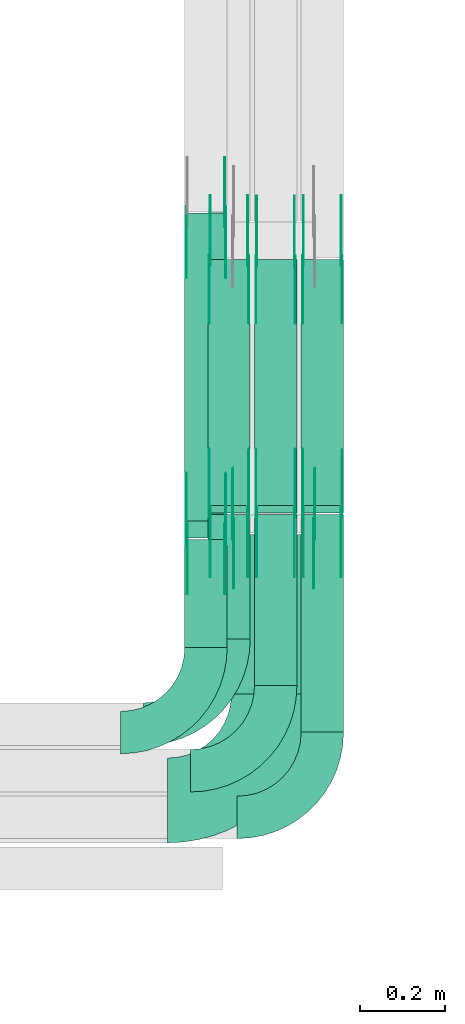
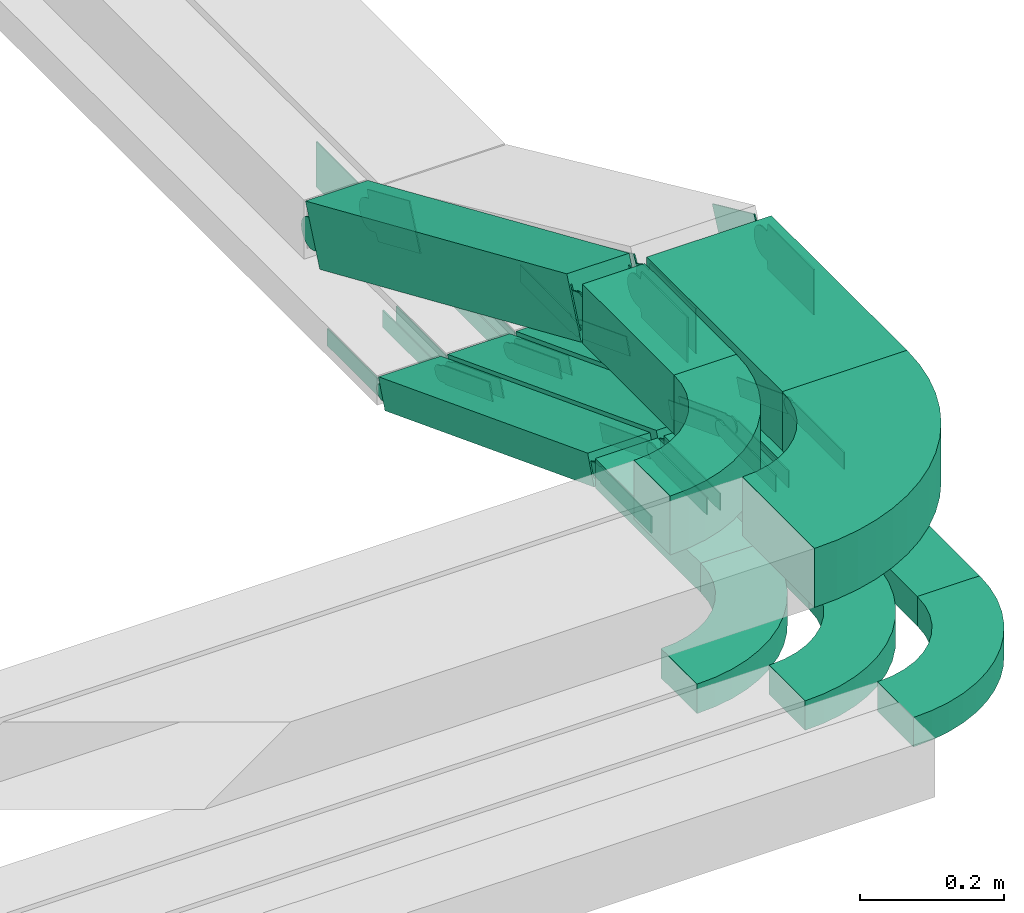
# One storey, part 19 of 25: 40 flow fittings, 9 flow segments.
"""IFC2X3 building model written with IfcOpenShell, lengths in millimetres."""

from ifc_helpers import new_model, entity, si_unit, converted_unit, derived_unit, direction, frame, frame_2d, origin, origin_2d_with_axis, place, context, subcontext, project, spatial, polyline, circle_curve, parameter, trimmed, segment, composite_curve, rectangle, outline, extrude, source, transform, mapped, material, type_object, type_shapes, element, save


model = new_model("IFC2X3")

# Units and contexts
model_context = context("Model", 3, precision=0.01, world=origin(), true_north=direction((6.12303176911189e-17, 1.0)))
body_context = subcontext(model_context, "Body", "Model", "MODEL_VIEW")
ifc_project = project(units=[si_unit("LENGTHUNIT", "METRE", prefix="MILLI"), si_unit("AREAUNIT", "SQUARE_METRE"), si_unit("VOLUMEUNIT", "CUBIC_METRE"), converted_unit("PLANEANGLEUNIT", "DEGREE", entity("IfcRatioMeasure", 0.0174532925199433), si_unit("PLANEANGLEUNIT", "RADIAN"), dimensions=[0, 0, 0, 0, 0, 0, 0]), si_unit("MASSUNIT", "GRAM", prefix="KILO"), derived_unit("MASSDENSITYUNIT", [(si_unit("MASSUNIT", "GRAM", prefix="KILO"), 1), (si_unit("LENGTHUNIT", "METRE"), -3)]), derived_unit("MOMENTOFINERTIAUNIT", [(si_unit("LENGTHUNIT", "METRE"), 4)]), si_unit("TIMEUNIT", "SECOND"), si_unit("FREQUENCYUNIT", "HERTZ"), si_unit("THERMODYNAMICTEMPERATUREUNIT", "DEGREE_CELSIUS"), derived_unit("THERMALTRANSMITTANCEUNIT", [(si_unit("MASSUNIT", "GRAM", prefix="KILO"), 1), (si_unit("THERMODYNAMICTEMPERATUREUNIT", "KELVIN"), -1), (si_unit("TIMEUNIT", "SECOND"), -3)]), derived_unit("VOLUMETRICFLOWRATEUNIT", [(si_unit("LENGTHUNIT", "METRE"), 3), (si_unit("TIMEUNIT", "SECOND"), -1)]), derived_unit("MASSFLOWRATEUNIT", [(si_unit("MASSUNIT", "GRAM", prefix="KILO"), 1), (si_unit("TIMEUNIT", "SECOND"), -1)]), derived_unit("ROTATIONALFREQUENCYUNIT", [(si_unit("TIMEUNIT", "SECOND"), -1)]), si_unit("ELECTRICCURRENTUNIT", "AMPERE"), si_unit("ELECTRICVOLTAGEUNIT", "VOLT"), si_unit("POWERUNIT", "WATT"), si_unit("FORCEUNIT", "NEWTON", prefix="KILO"), si_unit("ILLUMINANCEUNIT", "LUX"), si_unit("LUMINOUSFLUXUNIT", "LUMEN"), si_unit("LUMINOUSINTENSITYUNIT", "CANDELA"), derived_unit("USERDEFINED", [(si_unit("MASSUNIT", "GRAM", prefix="KILO"), -1), (si_unit("LENGTHUNIT", "METRE"), -2), (si_unit("TIMEUNIT", "SECOND"), 3), (si_unit("LUMINOUSFLUXUNIT", "LUMEN"), 1)]), derived_unit("LINEARVELOCITYUNIT", [(si_unit("LENGTHUNIT", "METRE"), 1), (si_unit("TIMEUNIT", "SECOND"), -1)]), si_unit("PRESSUREUNIT", "PASCAL"), derived_unit("USERDEFINED", [(si_unit("LENGTHUNIT", "METRE"), -2), (si_unit("MASSUNIT", "GRAM", prefix="KILO"), 1), (si_unit("TIMEUNIT", "SECOND"), -2)]), derived_unit("LINEARFORCEUNIT", [(si_unit("MASSUNIT", "GRAM", prefix="KILO"), 1), (si_unit("LENGTHUNIT", "METRE"), 1), (si_unit("TIMEUNIT", "SECOND"), -2), (si_unit("LENGTHUNIT", "METRE"), -1)]), derived_unit("PLANARFORCEUNIT", [(si_unit("MASSUNIT", "GRAM", prefix="KILO"), 1), (si_unit("LENGTHUNIT", "METRE"), 1), (si_unit("TIMEUNIT", "SECOND"), -2), (si_unit("LENGTHUNIT", "METRE"), -2)])], contexts=[model_context])

# Site, building, storey
site_placement = place(None, frame((0.0, -0.00077364408347762, 0.0)))
site = spatial("IfcSite", under=ifc_project, at=site_placement, CompositionType="ELEMENT")
building_placement = place(site_placement, origin())
building = spatial("IfcBuilding", under=site, at=building_placement, CompositionType="ELEMENT")
storey_placement = place(building_placement, frame((0.0, 0.0, 24000.0)))
storey = spatial("IfcBuildingStorey", under=building, at=storey_placement, CompositionType="ELEMENT", Elevation=24000.0)

# Flow segments
cable_carrier_segment_type = type_object("IfcCableCarrierSegmentType", PredefinedType="CABLETRAYSEGMENT")
flow_segment_1_placement = place(storey_placement, frame((67299.5040918465, 1750.69184714184, 3217.23038971969)))
element("IfcFlowSegment", 1, at=flow_segment_1_placement, inside=storey, type_object=cable_carrier_segment_type, context=body_context, shape_type="SweptSolid", body=[
    extrude(rectangle(XDim=292.631754544286, YDim=99.9999999999946, at=frame_2d((-2.70006239588838e-13, 0.0), x_axis=(1.0, 0.0))), frame((50.0, 146.315877272143, 0.0), z_axis=(0.0, 0.0, 1.0), x_axis=(0.0, 1.0, 0.0)), (0.0, 0.0, 1.0), 49.9999999999973),
])
flow_segment_2_placement = place(storey_placement, frame((67409.5040918465, 1640.69184714184, 3217.23038971969)))
element("IfcFlowSegment", 2, at=flow_segment_2_placement, inside=storey, type_object=cable_carrier_segment_type, context=body_context, shape_type="SweptSolid", body=[
    extrude(rectangle(XDim=402.62516769704, YDim=99.9999999999946, at=frame_2d((0.0, -4.33075797445781e-12), x_axis=(1.0, 0.0))), frame((50.0, 201.312583848523, 0.0), z_axis=(0.0, 0.0, 1.0), x_axis=(0.0, 1.0, 0.0)), (0.0, 0.0, 1.0), 49.9999999999973),
])
flow_segment_3_placement = place(storey_placement, frame((67519.5040918465, 1530.69184714184, 3217.23038971969)))
element("IfcFlowSegment", 3, at=flow_segment_3_placement, inside=storey, type_object=cable_carrier_segment_type, context=body_context, shape_type="SweptSolid", body=[
    extrude(rectangle(XDim=512.631754544286, YDim=99.9999999999946, at=origin_2d_with_axis()), frame((50.0, 256.315877272145, 0.0), z_axis=(0.0, 0.0, 1.0), x_axis=(0.0, 1.0, 0.0)), (0.0, 0.0, 1.0), 49.9999999999973),
])
flow_segment_4_placement = place(storey_placement, frame((67299.5040918465, 2046.68917097332, 2994.01409348303)))
element("IfcFlowSegment", 4, at=flow_segment_4_placement, inside=storey, type_object=cable_carrier_segment_type, context=body_context, shape_type="SweptSolid", body=[
    extrude(rectangle(XDim=50.0000000000003, YDim=621.842110546752, at=frame_2d((-8.81072992342524e-13, 1.97175609173428e-12), x_axis=(0.0, 1.0))), frame((0.0, 299.267667784553, 134.640087900776), z_axis=(1.0, 0.0, 0.0), x_axis=(0.0, -0.933737730629972, 0.357957889140595)), (0.0, 0.0, 1.0), 99.9999999999946),
])
flow_segment_5_placement = place(storey_placement, frame((67409.5040918464, 2046.68406706356, 2994.02299796659)))
element("IfcFlowSegment", 5, at=flow_segment_5_placement, inside=storey, type_object=cable_carrier_segment_type, context=body_context, shape_type="SweptSolid", body=[
    extrude(rectangle(XDim=50.0, YDim=621.102824044188, at=frame_2d((7.95807864051312e-13, -2.02327044007689e-12), x_axis=(0.0, 1.0))), frame((0.0, 298.883918423522, 134.631183417203), z_axis=(1.0, 0.0, 0.0), x_axis=(0.0, -0.933580426497182, 0.358367949545352)), (0.0, 0.0, 1.0), 99.9999999999945),
])
flow_segment_6_placement = place(storey_placement, frame((67519.5040918465, 2046.68917097332, 2994.01409348303)))
element("IfcFlowSegment", 6, at=flow_segment_6_placement, inside=storey, type_object=cable_carrier_segment_type, context=body_context, shape_type="SweptSolid", body=[
    extrude(rectangle(XDim=50.0000000000004, YDim=621.842110546751, at=frame_2d((-5.40012479177676e-13, 2.1156409957257e-12), x_axis=(0.0, 1.0))), frame((0.0, 299.267667784553, 134.640087900776), z_axis=(1.0, 0.0, 0.0), x_axis=(0.0, -0.933737730629971, 0.357957889140596)), (0.0, 0.0, 1.0), 99.9999999999946),
])
flow_segment_7_placement = place(storey_placement, frame((67245.1118837392, 1730.69184714192, 3517.23038971969)))
element("IfcFlowSegment", 7, at=flow_segment_7_placement, inside=storey, type_object=cable_carrier_segment_type, context=body_context, shape_type="SweptSolid", body=[
    extrude(rectangle(XDim=254.10672619877, YDim=99.9999999999946, at=origin_2d_with_axis()), frame((50.0, 127.053363099389, 0.0), z_axis=(0.0, 0.0, 1.0), x_axis=(0.0, 1.0, 0.0)), (0.0, 0.0, 1.0), 100.000000000003),
])
flow_segment_8_placement = place(storey_placement, frame((67355.1118837392, 1620.69184714191, 3517.23038971969)))
element("IfcFlowSegment", 8, at=flow_segment_8_placement, inside=storey, type_object=cable_carrier_segment_type, context=body_context, shape_type="SweptSolid", body=[
    extrude(rectangle(XDim=376.244460729016, YDim=200.000000000007, at=frame_2d((0.0, -4.33431068813661e-12), x_axis=(1.0, 0.0))), frame((100.0, 188.12223036451, 0.0), z_axis=(0.0, 0.0, 1.0), x_axis=(0.0, 1.0, 0.0)), (0.0, 0.0, 1.0), 100.000000000003),
])
flow_segment_9_placement = place(storey_placement, frame((67245.1118837392, 1988.31468735971, 3199.96690637507)))
element("IfcFlowSegment", 9, at=flow_segment_9_placement, inside=storey, type_object=cable_carrier_segment_type, context=body_context, shape_type="SweptSolid", body=[
    extrude(rectangle(XDim=99.9999999999994, YDim=99.9999999999946, at=origin_2d_with_axis()), frame((50.0, 19.9943720426684, 362.358065706302), z_axis=(0.0, 0.916564255602272, -0.399887440853364), x_axis=(0.0, 0.399887440853364, 0.916564255602272)), (0.0, 0.0, 1.0), 791.547372057253),
])

# Flow fittings
ifc_material_1 = material(Name="G")
cable_carrier_fitting_type_1 = type_object("IfcCableCarrierFittingType", PredefinedType="NOTDEFINED", material=ifc_material_1)
shared_shape_1 = source(origin(), body_context, "Body", "SweptSolid", [
    extrude(outline(composite_curve([segment(trimmed(circle_curve(frame_2d((-44.5901162790698, 0.0), x_axis=(1.0, 0.0)), 12.5), [parameter(90.0000000000007)], [parameter(270.0)], True, "PARAMETER"), True, "CONTINUOUS"), segment(polyline([(-44.5901162790697, -12.5), (-33.0901162790698, -12.5)]), True, "CONTINUOUS"), segment(polyline([(-33.0901162790698, -12.5), (-31.2296511627907, -14.5)]), True, "CONTINUOUS"), segment(polyline([(-31.2296511627907, -14.5), (108.90988372093, -14.5)]), True, "CONTINUOUS"), segment(polyline([(108.90988372093, -14.5), (108.90988372093, 14.5)]), True, "CONTINUOUS"), segment(polyline([(108.90988372093, 14.5), (-31.2296511627907, 14.5)]), True, "CONTINUOUS"), segment(polyline([(-31.2296511627907, 14.5), (-33.0901162790698, 12.5)]), True, "CONTINUOUS"), segment(polyline([(-33.0901162790698, 12.5), (-44.5901162790699, 12.5)]), True, "CONTINUOUS")], self_intersect=False)), frame((44.5901162790698, 0.0, 0.0), z_axis=(0.0, 0.0, -1.0), x_axis=(1.0, 0.0, 0.0)), (0.0, 0.0, -1.0), 2.0),
])
type_shapes(cable_carrier_fitting_type_1, [shared_shape_1])
for number, where, z_axis, x_axis in (
    (10, (67414.0440918363, 2641.44412383227, 3015.07797304788), (-1.0, 0.0, 0.0), (0.0, -0.933580426497204, 0.358367949545295)),
    (11, (67414.0440918363, 2049.69184714189, 3242.23038971971), (-1.0, 0.0, 0.0), (0.0, 0.933580426497204, -0.358367949545295)),
    (12, (67304.0440918363, 2642.22183037388, 3015.07797304788), (-1.0, 0.0, 0.0), (0.0, -0.93373773062991, 0.357957889140756)),
    (13, (67304.0440918363, 2049.69184714188, 3242.23038971971), (-1.0, 0.0, 0.0), (0.0, 0.93373773062991, -0.357957889140756)),
    (14, (67524.0440918363, 2642.22183037388, 3015.07797304788), (-1.0, 0.0, 0.0), (0.0, -0.93373773062991, 0.357957889140756)),
    (15, (67524.0440918363, 2049.69184714188, 3242.23038971971), (-1.0, 0.0, 0.0), (0.0, 0.93373773062991, -0.357957889140756)),
):
    element("IfcFlowFitting", number, at=place(storey_placement, frame(where, z_axis=z_axis, x_axis=x_axis)), inside=storey, type_object=cable_carrier_fitting_type_1, material=ifc_material_1, context=body_context, shape_type="MappedRepresentation", body=[
        mapped(shared_shape_1, transform((0.0, 0.0, 0.0), scale=1.0)),
    ])
cable_carrier_fitting_type_2 = type_object("IfcCableCarrierFittingType", PredefinedType="NOTDEFINED", material=ifc_material_1)
shared_shape_2 = source(origin(), body_context, "Body", "SweptSolid", [
    extrude(outline(composite_curve([segment(trimmed(circle_curve(frame_2d((-44.5901162790697, 0.0), x_axis=(1.0, 0.0)), 12.5), [parameter(90.0000000000007)], [parameter(270.0)], True, "PARAMETER"), True, "CONTINUOUS"), segment(polyline([(-44.5901162790697, -12.5), (-33.0901162790697, -12.5)]), True, "CONTINUOUS"), segment(polyline([(-33.0901162790697, -12.5), (-31.2296511627907, -14.5)]), True, "CONTINUOUS"), segment(polyline([(-31.2296511627907, -14.5), (108.90988372093, -14.5)]), True, "CONTINUOUS"), segment(polyline([(108.90988372093, -14.5), (108.90988372093, 14.5)]), True, "CONTINUOUS"), segment(polyline([(108.90988372093, 14.5), (-31.2296511627907, 14.5)]), True, "CONTINUOUS"), segment(polyline([(-31.2296511627907, 14.5), (-33.0901162790698, 12.5)]), True, "CONTINUOUS"), segment(polyline([(-33.0901162790698, 12.5), (-44.5901162790699, 12.5)]), True, "CONTINUOUS")], self_intersect=False)), frame((44.5901162790697, 0.0, 0.0)), (0.0, 0.0, 1.0), 2.0),
])
type_shapes(cable_carrier_fitting_type_2, [shared_shape_2])
for number, where, z_axis, x_axis in (
    (16, (67504.9640918566, 2641.44412383227, 3015.07797304788), (1.0, 0.0, 0.0), (0.0, -0.933580426497204, 0.358367949545295)),
    (17, (67504.9640918566, 2049.69184714189, 3242.23038971971), (1.0, 0.0, 0.0), (0.0, 0.933580426497204, -0.358367949545295)),
    (18, (67394.9640918566, 2642.22183037388, 3015.07797304788), (1.0, 0.0, 0.0), (0.0, -0.93373773062991, 0.357957889140756)),
    (19, (67394.9640918566, 2049.69184714187, 3242.23038971971), (1.0, 0.0, 0.0), (0.0, 0.93373773062991, -0.357957889140756)),
    (20, (67614.9640918566, 2642.22183037388, 3015.07797304788), (1.0, 0.0, 0.0), (0.0, -0.93373773062991, 0.357957889140756)),
    (21, (67614.9640918566, 2049.69184714188, 3242.23038971971), (1.0, 0.0, 0.0), (0.0, 0.93373773062991, -0.357957889140756)),
):
    element("IfcFlowFitting", number, at=place(storey_placement, frame(where, z_axis=z_axis, x_axis=x_axis)), inside=storey, type_object=cable_carrier_fitting_type_2, material=ifc_material_1, context=body_context, shape_type="MappedRepresentation", body=[
        mapped(shared_shape_2, transform((0.0, 0.0, 0.0), scale=1.0)),
    ])
cable_carrier_fitting_type_3 = type_object("IfcCableCarrierFittingType", PredefinedType="NOTDEFINED", material=ifc_material_1)
shared_shape_3 = source(origin(), body_context, "Body", "SweptSolid", [
    extrude(outline(composite_curve([segment(trimmed(circle_curve(frame_2d((-44.5901162790698, 0.0), x_axis=(1.0, 0.0)), 12.5), [parameter(90.0000000000007)], [parameter(270.0)], True, "PARAMETER"), True, "CONTINUOUS"), segment(polyline([(-44.5901162790697, -12.5), (-33.0901162790698, -12.5)]), True, "CONTINUOUS"), segment(polyline([(-33.0901162790698, -12.5), (-31.2296511627907, -14.5)]), True, "CONTINUOUS"), segment(polyline([(-31.2296511627907, -14.5), (108.90988372093, -14.5)]), True, "CONTINUOUS"), segment(polyline([(108.90988372093, -14.5), (108.90988372093, 14.5)]), True, "CONTINUOUS"), segment(polyline([(108.90988372093, 14.5), (-31.2296511627907, 14.5)]), True, "CONTINUOUS"), segment(polyline([(-31.2296511627907, 14.5), (-33.0901162790698, 12.5)]), True, "CONTINUOUS"), segment(polyline([(-33.0901162790698, 12.5), (-44.5901162790699, 12.5)]), True, "CONTINUOUS")], self_intersect=False)), frame((44.5901162790698, 0.0, 0.0), z_axis=(0.0, 0.0, -1.0), x_axis=(1.0, 0.0, 0.0)), (0.0, 0.0, -1.0), 2.0),
])
type_shapes(cable_carrier_fitting_type_3, [shared_shape_3])
for number, where, z_axis, x_axis in (
    (22, (67502.9640918566, 2641.44412383226, 3015.07797304789), (1.0, 0.0, 0.0), (0.0, 1.0, 0.0)),
    (23, (67502.9640918566, 2049.6918471419, 3242.23038971971), (1.0, 0.0, 0.0), (0.0, -1.0, 0.0)),
    (24, (67392.9640918566, 2642.22183037386, 3015.07797304789), (1.0, 0.0, 0.0), (0.0, 1.0, 0.0)),
    (25, (67392.9640918566, 2049.69184714189, 3242.23038971971), (1.0, 0.0, 0.0), (0.0, -1.0, 0.0)),
    (26, (67612.9640918566, 2642.22183037386, 3015.07797304789), (1.0, 0.0, 0.0), (0.0, 1.0, 0.0)),
    (27, (67612.9640918566, 2049.69184714189, 3242.23038971971), (1.0, 0.0, 0.0), (0.0, -1.0, 0.0)),
):
    element("IfcFlowFitting", number, at=place(storey_placement, frame(where, z_axis=z_axis, x_axis=x_axis)), inside=storey, type_object=cable_carrier_fitting_type_3, material=ifc_material_1, context=body_context, shape_type="MappedRepresentation", body=[
        mapped(shared_shape_3, transform((0.0, 0.0, 0.0), scale=1.0)),
    ])
cable_carrier_fitting_type_4 = type_object("IfcCableCarrierFittingType", PredefinedType="NOTDEFINED", material=ifc_material_1)
shared_shape_4 = source(origin(), body_context, "Body", "SweptSolid", [
    extrude(outline(composite_curve([segment(trimmed(circle_curve(frame_2d((-44.5901162790697, 0.0), x_axis=(1.0, 0.0)), 12.5), [parameter(90.0000000000007)], [parameter(270.0)], True, "PARAMETER"), True, "CONTINUOUS"), segment(polyline([(-44.5901162790697, -12.5), (-33.0901162790697, -12.5)]), True, "CONTINUOUS"), segment(polyline([(-33.0901162790697, -12.5), (-31.2296511627907, -14.5)]), True, "CONTINUOUS"), segment(polyline([(-31.2296511627907, -14.5), (108.90988372093, -14.5)]), True, "CONTINUOUS"), segment(polyline([(108.90988372093, -14.5), (108.90988372093, 14.5)]), True, "CONTINUOUS"), segment(polyline([(108.90988372093, 14.5), (-31.2296511627907, 14.5)]), True, "CONTINUOUS"), segment(polyline([(-31.2296511627907, 14.5), (-33.0901162790698, 12.5)]), True, "CONTINUOUS"), segment(polyline([(-33.0901162790698, 12.5), (-44.5901162790699, 12.5)]), True, "CONTINUOUS")], self_intersect=False)), frame((44.5901162790697, 0.0, 0.0)), (0.0, 0.0, 1.0), 2.0),
])
type_shapes(cable_carrier_fitting_type_4, [shared_shape_4])
for number, where, z_axis, x_axis in (
    (28, (67416.0440918363, 2641.44412383226, 3015.07797304789), (-1.0, 0.0, 0.0), (0.0, 1.0, 0.0)),
    (29, (67416.0440918363, 2049.6918471419, 3242.2303897197), (-1.0, 0.0, 0.0), (0.0, -1.0, 0.0)),
    (30, (67306.0440918363, 2642.22183037386, 3015.07797304789), (-1.0, 0.0, 0.0), (0.0, 1.0, 0.0)),
    (31, (67306.0440918363, 2049.69184714189, 3242.2303897197), (-1.0, 0.0, 0.0), (0.0, -1.0, 0.0)),
    (32, (67526.0440918363, 2642.22183037386, 3015.07797304789), (-1.0, 0.0, 0.0), (0.0, 1.0, 0.0)),
    (33, (67526.0440918363, 2049.69184714189, 3242.2303897197), (-1.0, 0.0, 0.0), (0.0, -1.0, 0.0)),
):
    element("IfcFlowFitting", number, at=place(storey_placement, frame(where, z_axis=z_axis, x_axis=x_axis)), inside=storey, type_object=cable_carrier_fitting_type_4, material=ifc_material_1, context=body_context, shape_type="MappedRepresentation", body=[
        mapped(shared_shape_4, transform((0.0, 0.0, 0.0), scale=1.0)),
    ])
cable_carrier_fitting_type_5 = type_object("IfcCableCarrierFittingType", PredefinedType="NOTDEFINED", material=ifc_material_1)
shared_shape_5 = source(origin(), body_context, "Body", "SweptSolid", [
    extrude(outline(composite_curve([segment(trimmed(circle_curve(frame_2d((-41.4651162790697, 0.0), x_axis=(1.0, 0.0)), 25.0), [parameter(90.0000000000007)], [parameter(270.0)], True, "PARAMETER"), True, "CONTINUOUS"), segment(polyline([(-41.4651162790697, -25.0), (-29.9651162790697, -25.0)]), True, "CONTINUOUS"), segment(polyline([(-29.9651162790697, -25.0), (-28.1046511627907, -38.5)]), True, "CONTINUOUS"), segment(polyline([(-28.1046511627907, -38.5), (99.5348837209303, -38.5)]), True, "CONTINUOUS"), segment(polyline([(99.5348837209303, -38.5), (99.5348837209303, 38.5)]), True, "CONTINUOUS"), segment(polyline([(99.5348837209303, 38.5), (-28.1046511627907, 38.5)]), True, "CONTINUOUS"), segment(polyline([(-28.1046511627907, 38.5), (-29.9651162790697, 25.0)]), True, "CONTINUOUS"), segment(polyline([(-29.9651162790697, 25.0), (-41.46511627907, 25.0)]), True, "CONTINUOUS")], self_intersect=False)), frame((41.4651162790697, 0.0, 0.0), z_axis=(0.0, 0.0, -1.0), x_axis=(1.0, 0.0, 0.0)), (0.0, 0.0, -1.0), 2.0),
])
type_shapes(cable_carrier_fitting_type_5, [shared_shape_5])
for number, where, z_axis, x_axis in (
    (34, (67249.651883729, 2745.05657730533, 3240.88970151684), (-1.0, 0.0, 0.0), (0.0, -0.916564255602269, 0.399887440853372)),
    (35, (67249.651883729, 1997.06556934302, 3567.23038971973), (-1.0, 0.0, 0.0), (0.0, 0.916564255602269, -0.399887440853372)),
    (36, (67359.651883729, 2009.69184714195, 3567.23038971972), (-1.0, 0.0, 0.0), (0.0, 0.909506231619165, -0.415690286927545)),
):
    element("IfcFlowFitting", number, at=place(storey_placement, frame(where, z_axis=z_axis, x_axis=x_axis)), inside=storey, type_object=cable_carrier_fitting_type_5, material=ifc_material_1, context=body_context, shape_type="MappedRepresentation", body=[
        mapped(shared_shape_5, transform((0.0, 0.0, 0.0), scale=1.0)),
    ])
cable_carrier_fitting_type_6 = type_object("IfcCableCarrierFittingType", PredefinedType="NOTDEFINED", material=ifc_material_1)
shared_shape_6 = source(origin(), body_context, "Body", "SweptSolid", [
    extrude(outline(composite_curve([segment(trimmed(circle_curve(frame_2d((-41.4651162790697, 0.0), x_axis=(1.0, 0.0)), 25.0), [parameter(90.0000000000007)], [parameter(270.0)], True, "PARAMETER"), True, "CONTINUOUS"), segment(polyline([(-41.4651162790697, -25.0), (-29.9651162790697, -25.0)]), True, "CONTINUOUS"), segment(polyline([(-29.9651162790697, -25.0), (-28.1046511627907, -38.5)]), True, "CONTINUOUS"), segment(polyline([(-28.1046511627907, -38.5), (99.5348837209303, -38.5)]), True, "CONTINUOUS"), segment(polyline([(99.5348837209303, -38.5), (99.5348837209303, 38.5)]), True, "CONTINUOUS"), segment(polyline([(99.5348837209303, 38.5), (-28.1046511627907, 38.5)]), True, "CONTINUOUS"), segment(polyline([(-28.1046511627907, 38.5), (-29.9651162790697, 25.0)]), True, "CONTINUOUS"), segment(polyline([(-29.9651162790697, 25.0), (-41.46511627907, 25.0)]), True, "CONTINUOUS")], self_intersect=False)), frame((41.4651162790697, 0.0, 0.0)), (0.0, 0.0, 1.0), 2.0),
])
type_shapes(cable_carrier_fitting_type_6, [shared_shape_6])
for number, where, z_axis, x_axis in (
    (37, (67340.5718837493, 2745.05657730533, 3240.88970151684), (1.0, 0.0, 0.0), (0.0, -0.916564255602269, 0.399887440853372)),
    (38, (67340.5718837493, 1997.06556934302, 3567.23038971973), (1.0, 0.0, 0.0), (0.0, 0.916564255602269, -0.399887440853372)),
    (39, (67550.5718837493, 2009.69184714195, 3567.23038971972), (1.0, 0.0, 0.0), (0.0, 0.909506231619165, -0.415690286927545)),
):
    element("IfcFlowFitting", number, at=place(storey_placement, frame(where, z_axis=z_axis, x_axis=x_axis)), inside=storey, type_object=cable_carrier_fitting_type_6, material=ifc_material_1, context=body_context, shape_type="MappedRepresentation", body=[
        mapped(shared_shape_6, transform((0.0, 0.0, 0.0), scale=1.0)),
    ])
cable_carrier_fitting_type_7 = type_object("IfcCableCarrierFittingType", PredefinedType="NOTDEFINED", material=ifc_material_1)
shared_shape_7 = source(origin(), body_context, "Body", "SweptSolid", [
    extrude(outline(composite_curve([segment(trimmed(circle_curve(frame_2d((-41.4651162790697, 0.0), x_axis=(1.0, 0.0)), 25.0), [parameter(90.0000000000007)], [parameter(270.0)], True, "PARAMETER"), True, "CONTINUOUS"), segment(polyline([(-41.4651162790697, -25.0), (-29.9651162790697, -25.0)]), True, "CONTINUOUS"), segment(polyline([(-29.9651162790697, -25.0), (-28.1046511627907, -38.5)]), True, "CONTINUOUS"), segment(polyline([(-28.1046511627907, -38.5), (99.5348837209303, -38.5)]), True, "CONTINUOUS"), segment(polyline([(99.5348837209303, -38.5), (99.5348837209303, 38.5)]), True, "CONTINUOUS"), segment(polyline([(99.5348837209303, 38.5), (-28.1046511627907, 38.5)]), True, "CONTINUOUS"), segment(polyline([(-28.1046511627907, 38.5), (-29.9651162790697, 25.0)]), True, "CONTINUOUS"), segment(polyline([(-29.9651162790697, 25.0), (-41.46511627907, 25.0)]), True, "CONTINUOUS")], self_intersect=False)), frame((41.4651162790697, 0.0, 0.0), z_axis=(0.0, 0.0, -1.0), x_axis=(1.0, 0.0, 0.0)), (0.0, 0.0, -1.0), 2.0),
])
type_shapes(cable_carrier_fitting_type_7, [shared_shape_7])
for number, where, z_axis, x_axis in (
    (40, (67338.5718837493, 2745.05657730532, 3240.88970151684), (1.0, 0.0, 0.0), (0.0, 1.0, 0.0)),
    (41, (67338.5718837493, 1997.06556934303, 3567.23038971972), (1.0, 0.0, 0.0), (0.0, -1.0, 0.0)),
    (42, (67548.5718837493, 2009.69184714197, 3567.23038971971), (1.0, 0.0, 0.0), (0.0, -1.0, 0.0)),
):
    element("IfcFlowFitting", number, at=place(storey_placement, frame(where, z_axis=z_axis, x_axis=x_axis)), inside=storey, type_object=cable_carrier_fitting_type_7, material=ifc_material_1, context=body_context, shape_type="MappedRepresentation", body=[
        mapped(shared_shape_7, transform((0.0, 0.0, 0.0), scale=1.0)),
    ])
cable_carrier_fitting_type_8 = type_object("IfcCableCarrierFittingType", PredefinedType="NOTDEFINED", material=ifc_material_1)
shared_shape_8 = source(origin(), body_context, "Body", "SweptSolid", [
    extrude(outline(composite_curve([segment(trimmed(circle_curve(frame_2d((-41.4651162790697, 0.0), x_axis=(1.0, 0.0)), 25.0), [parameter(90.0000000000007)], [parameter(270.0)], True, "PARAMETER"), True, "CONTINUOUS"), segment(polyline([(-41.4651162790697, -25.0), (-29.9651162790697, -25.0)]), True, "CONTINUOUS"), segment(polyline([(-29.9651162790697, -25.0), (-28.1046511627907, -38.5)]), True, "CONTINUOUS"), segment(polyline([(-28.1046511627907, -38.5), (99.5348837209303, -38.5)]), True, "CONTINUOUS"), segment(polyline([(99.5348837209303, -38.5), (99.5348837209303, 38.5)]), True, "CONTINUOUS"), segment(polyline([(99.5348837209303, 38.5), (-28.1046511627907, 38.5)]), True, "CONTINUOUS"), segment(polyline([(-28.1046511627907, 38.5), (-29.9651162790697, 25.0)]), True, "CONTINUOUS"), segment(polyline([(-29.9651162790697, 25.0), (-41.46511627907, 25.0)]), True, "CONTINUOUS")], self_intersect=False)), frame((41.4651162790697, 0.0, 0.0)), (0.0, 0.0, 1.0), 2.0),
])
type_shapes(cable_carrier_fitting_type_8, [shared_shape_8])
for number, where, z_axis, x_axis in (
    (43, (67251.651883729, 1997.06556934303, 3567.23038971972), (-1.0, 0.0, 0.0), (0.0, -1.0, 0.0)),
    (44, (67361.651883729, 2009.69184714197, 3567.23038971971), (-1.0, 0.0, 0.0), (0.0, -1.0, 0.0)),
):
    element("IfcFlowFitting", number, at=place(storey_placement, frame(where, z_axis=z_axis, x_axis=x_axis)), inside=storey, type_object=cable_carrier_fitting_type_8, material=ifc_material_1, context=body_context, shape_type="MappedRepresentation", body=[
        mapped(shared_shape_8, transform((0.0, 0.0, 0.0), scale=1.0)),
    ])
ifc_material_2 = material()
cable_carrier_fitting_type_9 = type_object("IfcCableCarrierFittingType", Name="470_DKC_S5_Variable Angle Elbow 0-45:-", PredefinedType="NOTDEFINED", material=ifc_material_2)
shared_shape_9 = source(origin(), body_context, "Body", "SweptSolid", [
    extrude(outline(composite_curve([segment(polyline([(-125.750000000001, -225.25), (-124.749999999999, -225.25)]), True, "CONTINUOUS"), segment(trimmed(circle_curve(frame_2d((-124.75, 124.75), x_axis=(0.0, -1.0)), 350.0), [parameter(0.0)], [parameter(90.0000000000001)], True, "PARAMETER"), True, "CONTINUOUS"), segment(polyline([(225.25, 124.75), (225.25, 125.749999999999)]), True, "CONTINUOUS"), segment(polyline([(225.25, 125.749999999999), (25.25, 125.750000000001)]), True, "CONTINUOUS"), segment(polyline([(25.25, 125.750000000001), (25.25, 124.75)]), True, "CONTINUOUS"), segment(trimmed(circle_curve(frame_2d((-124.75, 124.75), x_axis=(0.0, -1.0)), 150.0), [parameter(0.0)], [parameter(90.0000000000001)], True, "PARAMETER"), False, "CONTINUOUS"), segment(polyline([(-124.749999999999, -25.2500000000003), (-125.750000000001, -25.2500000000003)]), True, "CONTINUOUS"), segment(polyline([(-125.750000000001, -25.2500000000003), (-125.750000000001, -225.25)]), True, "CONTINUOUS")], self_intersect=False)), frame((-125.249999999991, 125.249999999992, -50.0)), (0.0, 0.0, 1.0), 100.0),
])
type_shapes(cable_carrier_fitting_type_9, [shared_shape_9])
flow_fitting_1_placement = place(storey_placement, frame((67455.1118837392, 1369.69184714193, 3567.23038971969)))
element("IfcFlowFitting", 45, at=flow_fitting_1_placement, inside=storey, type_object=cable_carrier_fitting_type_9, material=ifc_material_2, Name="470_DKC_S5_Variable Angle Elbow 0-45:-", ObjectType="470_DKC_S5_Variable Angle Elbow 0-45:-", context=body_context, shape_type="MappedRepresentation", body=[
    mapped(shared_shape_9, transform((0.0, 0.0, 0.0), scale=1.0)),
])
cable_carrier_fitting_type_10 = type_object("IfcCableCarrierFittingType", Name="470_DKC_S5_Variable Angle Elbow 0-45:-", PredefinedType="NOTDEFINED", material=ifc_material_2)
shared_shape_10 = source(origin(), body_context, "Body", "SweptSolid", [
    extrude(outline(composite_curve([segment(polyline([(-100.749999999999, -150.250000000001), (-99.7499999999981, -150.250000000001)]), True, "CONTINUOUS"), segment(trimmed(circle_curve(frame_2d((-99.7500000000006, 99.7499999999987), x_axis=(0.0, -1.0)), 250.0), [parameter(0.0)], [parameter(90.0000000000001)], True, "PARAMETER"), True, "CONTINUOUS"), segment(polyline([(150.249999999999, 99.7500000000013), (150.249999999999, 100.750000000001)]), True, "CONTINUOUS"), segment(polyline([(150.249999999999, 100.750000000001), (50.2499999999992, 100.750000000001)]), True, "CONTINUOUS"), segment(polyline([(50.2499999999992, 100.750000000001), (50.2499999999992, 99.7500000000002)]), True, "CONTINUOUS"), segment(trimmed(circle_curve(frame_2d((-99.7500000000006, 99.7499999999987), x_axis=(0.0, -1.0)), 150.0), [parameter(0.0)], [parameter(90.0000000000001)], True, "PARAMETER"), False, "CONTINUOUS"), segment(polyline([(-99.7499999999989, -50.2500000000011), (-100.75, -50.2500000000011)]), True, "CONTINUOUS"), segment(polyline([(-100.75, -50.2500000000011), (-100.749999999999, -150.250000000001)]), True, "CONTINUOUS")], self_intersect=False)), frame((-100.249999999991, 100.249999999992, -50.0)), (0.0, 0.0, 1.0), 100.0),
])
type_shapes(cable_carrier_fitting_type_10, [shared_shape_10])
flow_fitting_2_placement = place(storey_placement, frame((67295.1118837392, 1529.69184714194, 3567.23038971969)))
element("IfcFlowFitting", 46, at=flow_fitting_2_placement, inside=storey, type_object=cable_carrier_fitting_type_10, material=ifc_material_2, Name="470_DKC_S5_Variable Angle Elbow 0-45:-", ObjectType="470_DKC_S5_Variable Angle Elbow 0-45:-", context=body_context, shape_type="MappedRepresentation", body=[
    mapped(shared_shape_10, transform((0.0, 0.0, 0.0), scale=1.0)),
])
cable_carrier_fitting_type_11 = type_object("IfcCableCarrierFittingType", Name="470_DKC_S5_Variable Angle Elbow 0-45:-", PredefinedType="NOTDEFINED", material=ifc_material_2)
shared_shape_11 = source(origin(), body_context, "Body", "SweptSolid", [
    extrude(outline(composite_curve([segment(polyline([(-100.750000000001, -150.25), (-99.7499999999994, -150.25)]), True, "CONTINUOUS"), segment(trimmed(circle_curve(frame_2d((-99.7499999999997, 99.7499999999995), x_axis=(0.0, -1.0)), 250.0), [parameter(0.0)], [parameter(90.0000000000001)], True, "PARAMETER"), True, "CONTINUOUS"), segment(polyline([(150.25, 99.75), (150.25, 100.749999999999)]), True, "CONTINUOUS"), segment(polyline([(150.25, 100.749999999999), (50.25, 100.75)]), True, "CONTINUOUS"), segment(polyline([(50.25, 100.75), (50.25, 99.7499999999998)]), True, "CONTINUOUS"), segment(trimmed(circle_curve(frame_2d((-99.7499999999997, 99.7499999999995), x_axis=(0.0, -1.0)), 150.0), [parameter(0.0)], [parameter(90.0000000000001)], True, "PARAMETER"), False, "CONTINUOUS"), segment(polyline([(-99.7499999999994, -50.2500000000003), (-100.750000000001, -50.2500000000003)]), True, "CONTINUOUS"), segment(polyline([(-100.750000000001, -50.2500000000003), (-100.750000000001, -150.25)]), True, "CONTINUOUS")], self_intersect=False)), frame((-100.249999999991, 100.249999999992, -25.0)), (0.0, 0.0, 1.0), 49.9999999999997),
])
type_shapes(cable_carrier_fitting_type_11, [shared_shape_11])
for number, where, name in (
    (47, (67349.5040918464, 1549.69184714186, 3242.23038971968), "470_DKC_S5_Variable Angle Elbow 0-45:-"),
    (48, (67459.5040918465, 1439.69184714186, 3242.23038971968), "470_DKC_S5_Variable Angle Elbow 0-45:-"),
    (49, (67569.5040918465, 1329.69184714186, 3242.23038971968), "470_DKC_S5_Variable Angle Elbow 0-45:-"),
):
    element("IfcFlowFitting", number, at=place(storey_placement, frame(where)), inside=storey, type_object=cable_carrier_fitting_type_11, material=ifc_material_2, Name=name, ObjectType="470_DKC_S5_Variable Angle Elbow 0-45:-", context=body_context, shape_type="MappedRepresentation", body=[
        mapped(shared_shape_11, transform((0.0, 0.0, 0.0), scale=1.0)),
    ])

save(model, "model.ifc")
